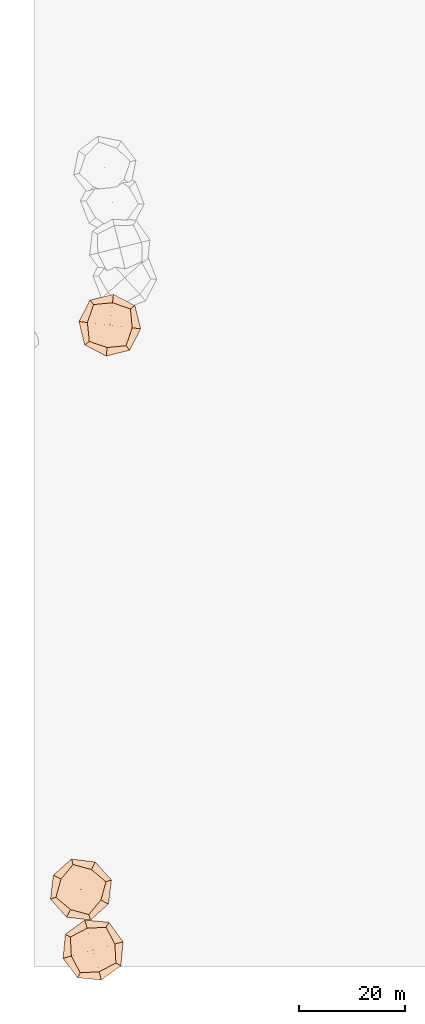
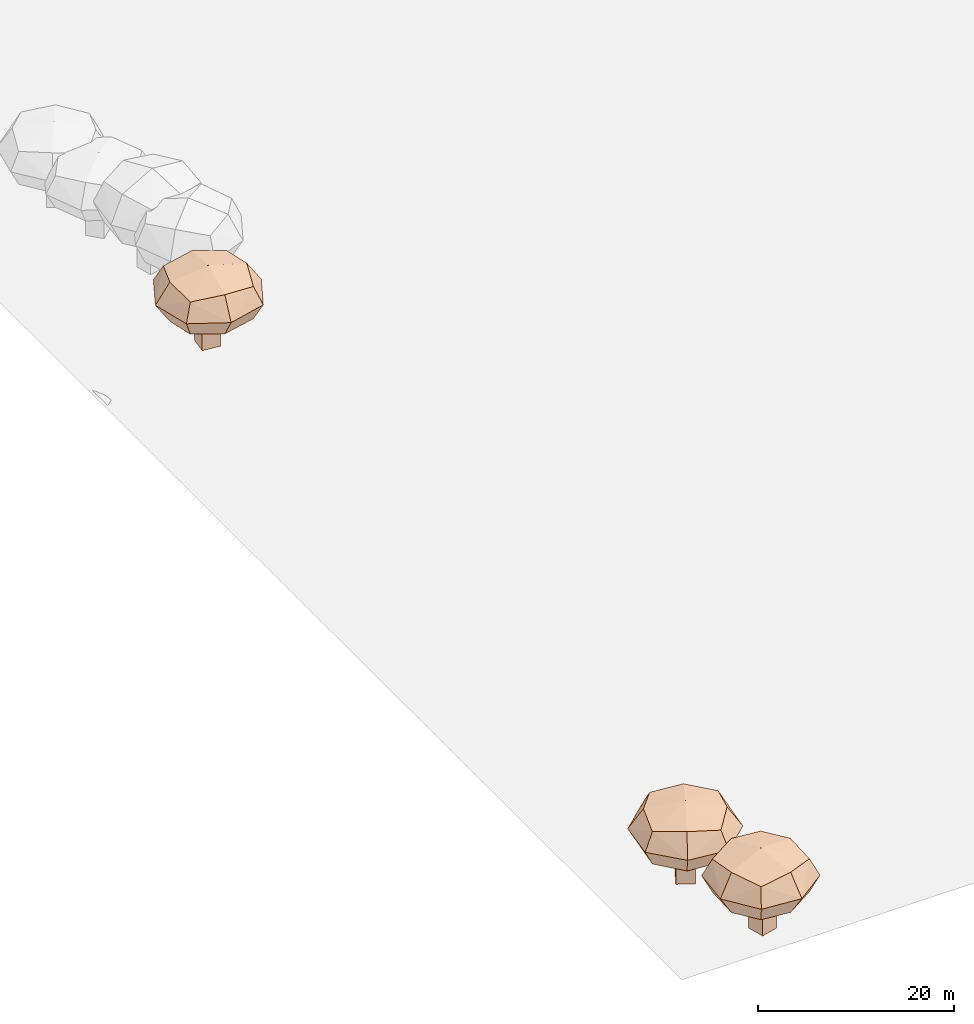
# Not in any storey, part 1 of 92: 3 geographic elements.
"""IFC4 model written with IfcOpenShell, lengths in metres."""

from ifc_helpers import new_model, si_unit, origin_with_axes, place, context, subcontext, project, spatial, triangles, material, element, save


model = new_model("IFC4")

# Units and contexts
model_context = context("Model", 3, precision=1e-05, world=origin_with_axes())
body_context = subcontext(model_context, "Body", "Model", "MODEL_VIEW")
ifc_project = project(units=[si_unit("VOLUMEUNIT", "CUBIC_METRE"), si_unit("LENGTHUNIT", "METRE"), si_unit("AREAUNIT", "SQUARE_METRE")], contexts=[model_context])

# Site
site_placement = place(None, origin_with_axes())
site = spatial("IfcSite", under=ifc_project, at=site_placement)

# Geographic elements
ifc_material = material(Name="tree")
geographic_element_1_placement = place(site_placement, origin_with_axes())
element("IfcGeographicElement", 1, at=geographic_element_1_placement, inside=site, material=ifc_material, Name="cw_instances_tree_201", context=body_context, shape_type="Tessellation", body=[
    triangles([(13.462260745399858, -775.030931593505, 5.714882036367992), (13.462260745399858, -775.030931593505, 5.714882036367992), (13.462260745399858, -775.030931593505, 5.714882036367992), (13.462260745399858, -775.030931593505, 0.0), (13.462260745399858, -775.030931593505, 0.0), (13.462260745399858, -775.030931593505, 0.0), (15.448455822864668, -775.2655144450832, 5.714882036367992), (15.448455822864668, -775.2655144450832, 5.714882036367992), (15.448455822864668, -775.2655144450832, 5.714882036367992), (15.448455822864668, -775.2655144450832, 0.0), (15.448455822864668, -775.2655144450832, 0.0), (15.448455822864668, -775.2655144450832, 0.0), (13.227677893821658, -777.0171266709699, 5.714882036367992), (13.227677893821658, -777.0171266709699, 5.714882036367992), (13.227677893821658, -777.0171266709699, 5.714882036367992), (13.227677893821658, -777.0171266709699, 0.0), (13.227677893821658, -777.0171266709699, 0.0), (13.227677893821658, -777.0171266709699, 0.0), (15.213872971286468, -777.251709522548, 5.714882036367992), (15.213872971286468, -777.251709522548, 5.714882036367992), (15.213872971286468, -777.251709522548, 5.714882036367992), (15.213872971286468, -777.251709522548, 0.0), (15.213872971286468, -777.251709522548, 0.0), (15.213872971286468, -777.251709522548, 0.0), (11.243569686765333, -772.5019902965017, 8.512689542772936), (11.243569686765333, -772.5019902965017, 8.512689542772936), (11.243569686765333, -772.5019902965017, 8.512689542772936), (11.243569686765333, -772.5019902965017, 8.512689542772936), (11.243569686765333, -772.5019902965017, 8.512689542772936), (11.243569686765333, -772.5019902965017, 8.512689542772936), (11.243569238228456, -772.5019900018584, 4.512272277332048), (11.243569238228456, -772.5019900018584, 4.512272277332048), (11.243569238228456, -772.5019900018584, 4.512272277332048), (11.243569238228456, -772.5019900018584, 4.512272277332048), (11.243569238228456, -772.5019900018584, 4.512272277332048), (11.243569238228456, -772.5019900018584, 4.512272277332048), (18.195250827569218, -773.3230298428053, 8.512689542772936), (18.195250827569218, -773.3230298428053, 8.512689542772936), (18.195250827569218, -773.3230298428053, 8.512689542772936), (18.195250827569218, -773.3230298428053, 8.512689542772936), (18.195250827569218, -773.3230298428053, 8.512689542772936), (18.195250827569218, -773.3230298428053, 8.512689542772936), (18.195250827569218, -773.3230298428053, 4.512272277332048), (18.195250827569218, -773.3230298428053, 4.512272277332048), (18.195250827569218, -773.3230298428053, 4.512272277332048), (18.195250827569218, -773.3230298428053, 4.512272277332048), (18.195250827569218, -773.3230298428053, 4.512272277332048), (18.195250827569218, -773.3230298428053, 4.512272277332048), (10.422529312831728, -779.4536723062294, 8.512689542772936), (10.422529312831728, -779.4536723062294, 8.512689542772936), (10.422529312831728, -779.4536723062294, 8.512689542772936), (10.422529312831728, -779.4536723062294, 8.512689542772936), (10.422529312831728, -779.4536723062294, 8.512689542772936), (10.422529312831728, -779.4536723062294, 8.512689542772936), (10.422529369131613, -779.4536718295426, 4.512272277332048), (10.422529369131613, -779.4536718295426, 4.512272277332048), (10.422529369131613, -779.4536718295426, 4.512272277332048), (10.422529369131613, -779.4536718295426, 4.512272277332048), (10.422529369131613, -779.4536718295426, 4.512272277332048), (10.422529369131613, -779.4536718295426, 4.512272277332048), (17.3742111405159, -780.2747121753263, 8.512689542772936), (17.3742111405159, -780.2747121753263, 8.512689542772936), (17.3742111405159, -780.2747121753263, 8.512689542772936), (17.3742111405159, -780.2747121753263, 8.512689542772936), (17.3742111405159, -780.2747121753263, 8.512689542772936), (17.3742111405159, -780.2747121753263, 8.512689542772936), (17.37421090217249, -780.2747121471763, 4.512272277332048), (17.37421090217249, -780.2747121471763, 4.512272277332048), (17.37421090217249, -780.2747121471763, 4.512272277332048), (17.37421090217249, -780.2747121471763, 4.512272277332048), (17.37421090217249, -780.2747121471763, 4.512272277332048), (17.37421090217249, -780.2747121471763, 4.512272277332048), (13.808410659658996, -780.6258731478587, 4.073955600388096), (13.808410659658996, -780.6258731478587, 4.073955600388096), (13.808410659658996, -780.6258731478587, 4.073955600388096), (13.808410659658996, -780.6258731478587, 4.073955600388096), (10.071368602726242, -775.8878715643513, 4.073955600388096), (10.071368602726242, -775.8878715643513, 4.073955600388096), (10.071368602726242, -775.8878715643513, 4.073955600388096), (10.071368602726242, -775.8878715643513, 4.073955600388096), (10.571848088103717, -771.6503500083585, 6.5124812529454355), (10.571848088103717, -771.6503500083585, 6.5124812529454355), (10.571848088103717, -771.6503500083585, 6.5124812529454355), (10.571848088103717, -771.6503500083585, 6.5124812529454355), (18.045932235513668, -781.126352635582, 6.5124812529454355), (18.045932235513668, -781.126352635582, 6.5124812529454355), (18.045932235513668, -781.126352635582, 6.5124812529454355), (18.045932235513668, -781.126352635582, 6.5124812529454355), (19.0468917914888, -772.651308575695, 6.5124812529454355), (19.0468917914888, -772.651308575695, 6.5124812529454355), (19.0468917914888, -772.651308575695, 6.5124812529454355), (19.0468917914888, -772.651308575695, 6.5124812529454355), (9.570889110311283, -780.1253931799298, 6.5124812529454355), (9.570889110311283, -780.1253931799298, 6.5124812529454355), (9.570889110311283, -780.1253931799298, 6.5124812529454355), (9.570889110311283, -780.1253931799298, 6.5124812529454355), (18.546412250984353, -776.8888305984435, 8.951005876823944), (18.546412250984353, -776.8888305984435, 8.951005876823944), (18.546412250984353, -776.8888305984435, 8.951005876823944), (18.546412250984353, -776.8888305984435, 8.951005876823944), (14.809369649568533, -772.1508290211156, 8.951007219821305), (14.809369649568533, -772.1508290211156, 8.951007219821305), (14.809369649568533, -772.1508290211156, 8.951007219821305), (14.809369649568533, -772.1508290211156, 8.951007219821305), (18.54641177836394, -776.8888305929714, 4.073955600388096), (18.54641177836394, -776.8888305929714, 4.073955600388096), (18.54641177836394, -776.8888305929714, 4.073955600388096), (18.54641177836394, -776.8888305929714, 4.073955600388096), (13.808410619935094, -780.625873143167, 8.951005876823944), (13.808410619935094, -780.625873143167, 8.951005876823944), (13.808410619935094, -780.625873143167, 8.951005876823944), (13.808410619935094, -780.625873143167, 8.951005876823944), (10.071368606244986, -775.8878715345583, 8.951007219821305), (10.071368606244986, -775.8878715345583, 8.951007219821305), (10.071368606244986, -775.8878715345583, 8.951007219821305), (10.071368606244986, -775.8878715345583, 8.951007219821305), (14.809369654027414, -772.1508294949089, 4.073955600388096), (14.809369654027414, -772.1508294949089, 4.073955600388096), (14.809369654027414, -772.1508294949089, 4.073955600388096), (14.809369654027414, -772.1508294949089, 4.073955600388096), (14.308890030163946, -776.3883511151015, 9.870856742856473), (14.308890030163946, -776.3883511151015, 9.870856742856473), (14.308890030163946, -776.3883511151015, 9.870856742856473), (14.308890030163946, -776.3883511151015, 9.870856742856473), (14.308890030163946, -776.3883511151015, 9.870856742856473), (14.308890030163946, -776.3883511151015, 9.870856742856473), (14.308890030163946, -776.3883511151015, 9.870856742856473), (14.308890030163946, -776.3883511151015, 9.870856742856473), (20.144869912691682, -777.0776190818432, 6.5124812529454355), (20.144869912691682, -777.0776190818432, 6.5124812529454355), (20.144869912691682, -777.0776190818432, 6.5124812529454355), (20.144869912691682, -777.0776190818432, 6.5124812529454355), (20.144869912691682, -777.0776190818432, 6.5124812529454355), (20.144869912691682, -777.0776190818432, 6.5124812529454355), (20.144869912691682, -777.0776190818432, 6.5124812529454355), (20.144869912691682, -777.0776190818432, 6.5124812529454355), (13.619622146466474, -782.2243308060472, 6.5124812529454355), (13.619622146466474, -782.2243308060472, 6.5124812529454355), (13.619622146466474, -782.2243308060472, 6.5124812529454355), (13.619622146466474, -782.2243308060472, 6.5124812529454355), (13.619622146466474, -782.2243308060472, 6.5124812529454355), (13.619622146466474, -782.2243308060472, 6.5124812529454355), (13.619622146466474, -782.2243308060472, 6.5124812529454355), (13.619622146466474, -782.2243308060472, 6.5124812529454355), (14.308890046584745, -776.3883509760678, 3.1541064202458697), (14.308890046584745, -776.3883509760678, 3.1541064202458697), (14.308890046584745, -776.3883509760678, 3.1541064202458697), (14.308890046584745, -776.3883509760678, 3.1541064202458697), (14.308890046584745, -776.3883509760678, 3.1541064202458697), (14.308890046584745, -776.3883509760678, 3.1541064202458697), (14.308890046584745, -776.3883509760678, 3.1541064202458697), (14.308890046584745, -776.3883509760678, 3.1541064202458697), (14.99815800832433, -770.5523718179537, 6.5124812529454355), (14.99815800832433, -770.5523718179537, 6.5124812529454355), (14.99815800832433, -770.5523718179537, 6.5124812529454355), (14.99815800832433, -770.5523718179537, 6.5124812529454355), (14.99815800832433, -770.5523718179537, 6.5124812529454355), (14.99815800832433, -770.5523718179537, 6.5124812529454355), (14.99815800832433, -770.5523718179537, 6.5124812529454355), (14.99815800832433, -770.5523718179537, 6.5124812529454355), (8.472910458467528, -775.6990830743066, 6.5124812529454355), (8.472910458467528, -775.6990830743066, 6.5124812529454355), (8.472910458467528, -775.6990830743066, 6.5124812529454355), (8.472910458467528, -775.6990830743066, 6.5124812529454355), (8.472910458467528, -775.6990830743066, 6.5124812529454355), (8.472910458467528, -775.6990830743066, 6.5124812529454355), (8.472910458467528, -775.6990830743066, 6.5124812529454355), (8.472910458467528, -775.6990830743066, 6.5124812529454355)], [[15, 8, 2], [7, 24, 11], [19, 16, 22], [4, 23, 17], [3, 12, 6], [14, 5, 18], [26, 127, 101], [54, 123, 114], [124, 66, 98], [128, 38, 102], [45, 133, 108], [40, 135, 89], [130, 63, 88], [131, 70, 105], [68, 141, 73], [61, 140, 86], [137, 49, 93], [142, 56, 74], [59, 145, 75], [31, 149, 79], [150, 43, 107], [146, 71, 76], [35, 154, 120], [30, 157, 83], [158, 42, 91], [153, 47, 119], [58, 164, 77], [51, 162, 96], [167, 28, 81], [165, 33, 80], [15, 21, 8], [7, 20, 24], [19, 13, 16], [4, 10, 23], [3, 9, 12], [14, 1, 5], [25, 115, 126], [53, 111, 121], [122, 112, 65], [125, 99, 37], [46, 90, 136], [39, 100, 134], [132, 97, 64], [129, 87, 69], [67, 85, 138], [62, 110, 144], [143, 109, 50], [139, 94, 55], [60, 78, 147], [32, 117, 151], [152, 118, 44], [148, 106, 72], [36, 84, 160], [29, 104, 156], [155, 103, 41], [159, 92, 48], [57, 95, 161], [52, 113, 163], [166, 116, 27], [168, 82, 34]], closed=True),
])
geographic_element_2_placement = place(site_placement, origin_with_axes())
element("IfcGeographicElement", 2, at=geographic_element_2_placement, inside=site, material=ifc_material, Name="cw_instances_tree_263", context=body_context, shape_type="Tessellation", body=[
    triangles([(8.543818649067786, -881.504173150315, 5.7320743896039135), (8.543818649067786, -881.504173150315, 5.7320743896039135), (8.543818649067786, -881.504173150315, 5.7320743896039135), (8.543818649067786, -881.504173150315, 0.0), (8.543818649067786, -881.504173150315, 0.0), (8.543818649067786, -881.504173150315, 0.0), (10.315363025021764, -882.432413703203, 5.7320743896039135), (10.315363025021764, -882.432413703203, 5.7320743896039135), (10.315363025021764, -882.432413703203, 5.7320743896039135), (10.315363025021764, -882.432413703203, 0.0), (10.315363025021764, -882.432413703203, 0.0), (10.315363025021764, -882.432413703203, 0.0), (7.61557809617978, -883.275717526269, 5.7320743896039135), (7.61557809617978, -883.275717526269, 5.7320743896039135), (7.61557809617978, -883.275717526269, 5.7320743896039135), (7.61557809617978, -883.275717526269, 0.0), (7.61557809617978, -883.275717526269, 0.0), (7.61557809617978, -883.275717526269, 0.0), (9.387122472133758, -884.2039580791569, 5.7320743896039135), (9.387122472133758, -884.2039580791569, 5.7320743896039135), (9.387122472133758, -884.2039580791569, 5.7320743896039135), (9.387122472133758, -884.2039580791569, 0.0), (9.387122472133758, -884.2039580791569, 0.0), (9.387122472133758, -884.2039580791569, 0.0), (7.374240064448537, -878.3497762140125, 8.538298674278316), (7.374240064448537, -878.3497762140125, 8.538298674278316), (7.374240064448537, -878.3497762140125, 8.538298674278316), (7.374240064448537, -878.3497762140125, 8.538298674278316), (7.374240064448537, -878.3497762140125, 8.538298674278316), (7.374240064448537, -878.3497762140125, 8.538298674278316), (7.374239750666753, -878.3497757786495, 4.5258467620536695), (7.374239750666753, -878.3497757786495, 4.5258467620536695), (7.374239750666753, -878.3497757786495, 4.5258467620536695), (7.374239750666753, -878.3497757786495, 4.5258467620536695), (7.374239750666753, -878.3497757786495, 4.5258467620536695), (7.374239750666753, -878.3497757786495, 4.5258467620536695), (13.57464401243677, -881.5986171614544, 8.538298674278316), (13.57464401243677, -881.5986171614544, 8.538298674278316), (13.57464401243677, -881.5986171614544, 8.538298674278316), (13.57464401243677, -881.5986171614544, 8.538298674278316), (13.57464401243677, -881.5986171614544, 8.538298674278316), (13.57464401243677, -881.5986171614544, 8.538298674278316), (13.57464401243677, -881.5986171614544, 4.5258467620536695), (13.57464401243677, -881.5986171614544, 4.5258467620536695), (13.57464401243677, -881.5986171614544, 4.5258467620536695), (13.57464401243677, -881.5986171614544, 4.5258467620536695), (13.57464401243677, -881.5986171614544, 4.5258467620536695), (13.57464401243677, -881.5986171614544, 4.5258467620536695), (4.125398033695262, -884.5501806781755, 8.538298674278316), (4.125398033695262, -884.5501806781755, 8.538298674278316), (4.125398033695262, -884.5501806781755, 8.538298674278316), (4.125398033695262, -884.5501806781755, 8.538298674278316), (4.125398033695262, -884.5501806781755, 8.538298674278316), (4.125398033695262, -884.5501806781755, 8.538298674278316), (4.1253982564729945, -884.5501802530049, 4.5258467620536695), (4.1253982564729945, -884.5501802530049, 4.5258467620536695), (4.1253982564729945, -884.5501802530049, 4.5258467620536695), (4.1253982564729945, -884.5501802530049, 4.5258467620536695), (4.1253982564729945, -884.5501802530049, 4.5258467620536695), (4.1253982564729945, -884.5501802530049, 4.5258467620536695), (10.325802508050607, -887.7990221723693, 8.538298674278316), (10.325802508050607, -887.7990221723693, 8.538298674278316), (10.325802508050607, -887.7990221723693, 8.538298674278316), (10.325802508050607, -887.7990221723693, 8.538298674278316), (10.325802508050607, -887.7990221723693, 8.538298674278316), (10.325802508050607, -887.7990221723693, 8.538298674278316), (10.325802295465282, -887.7990220609804, 4.5258467620536695), (10.325802295465282, -887.7990220609804, 4.5258467620536695), (10.325802295465282, -887.7990220609804, 4.5258467620536695), (10.325802295465282, -887.7990220609804, 4.5258467620536695), (10.325802295465282, -887.7990220609804, 4.5258467620536695), (10.325802295465282, -887.7990220609804, 4.5258467620536695), (6.8696316722635, -886.853966485246, 4.086211476065601), (6.8696316722635, -886.853966485246, 4.086211476065601), (6.8696316722635, -886.853966485246, 4.086211476065601), (6.8696316722635, -886.853966485246, 4.086211476065601), (5.070454059140944, -881.0940096922621, 4.086211476065601), (5.070454059140944, -881.0940096922621, 4.086211476065601), (5.070454059140944, -881.0940096922621, 4.086211476065601), (5.070454059140944, -881.0940096922621, 4.086211476065601), (7.050843295141966, -877.3144426368023, 6.532073062090477), (7.050843295141966, -877.3144426368023, 6.532073062090477), (7.050843295141966, -877.3144426368023, 6.532073062090477), (7.050843295141966, -877.3144426368023, 6.532073062090477), (10.649198745438863, -888.8343557305295, 6.532073062090477), (10.649198745438863, -888.8343557305295, 6.532073062090477), (10.649198745438863, -888.8343557305295, 6.532073062090477), (10.649198745438863, -888.8343557305295, 6.532073062090477), (14.609978102515313, -881.2752209431163, 6.532073062090477), (14.609978102515313, -881.2752209431163, 6.532073062090477), (14.609978102515313, -881.2752209431163, 6.532073062090477), (14.609978102515313, -881.2752209431163, 6.532073062090477), (3.0900647952927054, -884.8735768008684, 6.532073062090477), (3.0900647952927054, -884.8735768008684, 6.532073062090477), (3.0900647952927054, -884.8735768008684, 6.532073062090477), (3.0900647952927054, -884.8735768008684, 6.532073062090477), (12.629588648377762, -885.0547884148891, 8.9779336163419), (12.629588648377762, -885.0547884148891, 8.9779336163419), (12.629588648377762, -885.0547884148891, 8.9779336163419), (12.629588648377762, -885.0547884148891, 8.9779336163419), (10.830410524449807, -879.2948314332843, 8.977934963379463), (10.830410524449807, -879.2948314332843, 8.977934963379463), (10.830410524449807, -879.2948314332843, 8.977934963379463), (10.830410524449807, -879.2948314332843, 8.977934963379463), (12.62958820885882, -885.0547882410413, 4.086211476065601), (12.62958820885882, -885.0547882410413, 4.086211476065601), (12.62958820885882, -885.0547882410413, 4.086211476065601), (12.62958820885882, -885.0547882410413, 4.086211476065601), (6.8696316368326125, -886.8539664666813, 8.9779336163419), (6.8696316368326125, -886.8539664666813, 8.9779336163419), (6.8696316368326125, -886.8539664666813, 8.9779336163419), (6.8696316368326125, -886.8539664666813, 8.9779336163419), (5.070454073064552, -881.094009665689, 8.977934963379463), (5.070454073064552, -881.094009665689, 8.977934963379463), (5.070454073064552, -881.094009665689, 8.977934963379463), (5.070454073064552, -881.094009665689, 8.977934963379463), (10.830410359459608, -879.2948318774445, 4.086211476065601), (10.830410359459608, -879.2948318774445, 4.086211476065601), (10.830410359459608, -879.2948318774445, 4.086211476065601), (10.830410359459608, -879.2948318774445, 4.086211476065601), (8.850020971178578, -883.0743989434305, 9.900551713773531), (8.850020971178578, -883.0743989434305, 9.900551713773531), (8.850020971178578, -883.0743989434305, 9.900551713773531), (8.850020971178578, -883.0743989434305, 9.900551713773531), (8.850020971178578, -883.0743989434305, 9.900551713773531), (8.850020971178578, -883.0743989434305, 9.900551713773531), (8.850020971178578, -883.0743989434305, 9.900551713773531), (8.850020971178578, -883.0743989434305, 9.900551713773531), (14.05529889855752, -885.8018213929213, 6.532073062090477), (14.05529889855752, -885.8018213929213, 6.532073062090477), (14.05529889855752, -885.8018213929213, 6.532073062090477), (14.05529889855752, -885.8018213929213, 6.532073062090477), (14.05529889855752, -885.8018213929213, 6.532073062090477), (14.05529889855752, -885.8018213929213, 6.532073062090477), (14.05529889855752, -885.8018213929213, 6.532073062090477), (14.05529889855752, -885.8018213929213, 6.532073062090477), (6.122598667658213, -888.2796767215023, 6.532073062090477), (6.122598667658213, -888.2796767215023, 6.532073062090477), (6.122598667658213, -888.2796767215023, 6.532073062090477), (6.122598667658213, -888.2796767215023, 6.532073062090477), (6.122598667658213, -888.2796767215023, 6.532073062090477), (6.122598667658213, -888.2796767215023, 6.532073062090477), (6.122598667658213, -888.2796767215023, 6.532073062090477), (6.122598667658213, -888.2796767215023, 6.532073062090477), (8.850021036155416, -883.0743988194224, 3.1635950695960173), (8.850021036155416, -883.0743988194224, 3.1635950695960173), (8.850021036155416, -883.0743988194224, 3.1635950695960173), (8.850021036155416, -883.0743988194224, 3.1635950695960173), (8.850021036155416, -883.0743988194224, 3.1635950695960173), (8.850021036155416, -883.0743988194224, 3.1635950695960173), (8.850021036155416, -883.0743988194224, 3.1635950695960173), (8.850021036155416, -883.0743988194224, 3.1635950695960173), (11.577443222341344, -877.869121566929, 6.532073062090477), (11.577443222341344, -877.869121566929, 6.532073062090477), (11.577443222341344, -877.869121566929, 6.532073062090477), (11.577443222341344, -877.869121566929, 6.532073062090477), (11.577443222341344, -877.869121566929, 6.532073062090477), (11.577443222341344, -877.869121566929, 6.532073062090477), (11.577443222341344, -877.869121566929, 6.532073062090477), (11.577443222341344, -877.869121566929, 6.532073062090477), (3.6447433605845214, -880.3469765357409, 6.532073062090477), (3.6447433605845214, -880.3469765357409, 6.532073062090477), (3.6447433605845214, -880.3469765357409, 6.532073062090477), (3.6447433605845214, -880.3469765357409, 6.532073062090477), (3.6447433605845214, -880.3469765357409, 6.532073062090477), (3.6447433605845214, -880.3469765357409, 6.532073062090477), (3.6447433605845214, -880.3469765357409, 6.532073062090477), (3.6447433605845214, -880.3469765357409, 6.532073062090477)], [[15, 8, 2], [7, 24, 11], [19, 16, 22], [4, 23, 17], [3, 12, 6], [14, 5, 18], [26, 127, 101], [54, 123, 114], [124, 66, 98], [128, 38, 102], [45, 133, 108], [40, 135, 89], [130, 63, 88], [131, 70, 105], [68, 141, 73], [61, 140, 86], [137, 49, 93], [142, 56, 74], [59, 145, 75], [31, 149, 79], [150, 43, 107], [146, 71, 76], [35, 154, 120], [30, 157, 83], [158, 42, 91], [153, 47, 119], [58, 164, 77], [51, 162, 96], [167, 28, 81], [165, 33, 80], [15, 21, 8], [7, 20, 24], [19, 13, 16], [4, 10, 23], [3, 9, 12], [14, 1, 5], [25, 115, 126], [53, 111, 121], [122, 112, 65], [125, 99, 37], [46, 90, 136], [39, 100, 134], [132, 97, 64], [129, 87, 69], [67, 85, 138], [62, 110, 144], [143, 109, 50], [139, 94, 55], [60, 78, 147], [32, 117, 151], [152, 118, 44], [148, 106, 72], [36, 84, 160], [29, 104, 156], [155, 103, 41], [159, 92, 48], [57, 95, 161], [52, 113, 163], [166, 116, 27], [168, 82, 34]], closed=True),
])
geographic_element_3_placement = place(site_placement, origin_with_axes())
element("IfcGeographicElement", 3, at=geographic_element_3_placement, inside=site, material=ifc_material, Name="cw_instances_tree_266", context=body_context, shape_type="Tessellation", body=[
    triangles([(12.088299995210756, -893.2076391180938, 5.860105220273152), (12.088299995210756, -893.2076391180938, 5.860105220273152), (12.088299995210756, -893.2076391180938, 5.860105220273152), (12.088299995210756, -893.2076391180938, 0.0), (12.088299995210756, -893.2076391180938, 0.0), (12.088299995210756, -893.2076391180938, 0.0), (12.61907132279875, -895.1359237956791, 5.860105220273152), (12.61907132279875, -895.1359237956791, 5.860105220273152), (12.61907132279875, -895.1359237956791, 5.860105220273152), (12.61907132279875, -895.1359237956791, 0.0), (12.61907132279875, -895.1359237956791, 0.0), (12.61907132279875, -895.1359237956791, 0.0), (10.160015317625394, -893.7384104456818, 5.860105220273152), (10.160015317625394, -893.7384104456818, 5.860105220273152), (10.160015317625394, -893.7384104456818, 5.860105220273152), (10.160015317625394, -893.7384104456818, 0.0), (10.160015317625394, -893.7384104456818, 0.0), (10.160015317625394, -893.7384104456818, 0.0), (10.690786645213388, -895.6666951232671, 5.860105220273152), (10.690786645213388, -895.6666951232671, 5.860105220273152), (10.690786645213388, -895.6666951232671, 5.860105220273152), (10.690786645213388, -895.6666951232671, 0.0), (10.690786645213388, -895.6666951232671, 0.0), (10.690786645213388, -895.6666951232671, 0.0), (13.595363210061482, -890.1998335120418, 8.72900894729092), (13.595363210061482, -890.1998335120418, 8.72900894729092), (13.595363210061482, -890.1998335120418, 8.72900894729092), (13.595363210061482, -890.1998335120418, 8.72900894729092), (13.595363210061482, -890.1998335120418, 8.72900894729092), (13.595363210061482, -890.1998335120418, 8.72900894729092), (13.595363314070525, -890.1998329855609, 4.626935457182669), (13.595363314070525, -890.1998329855609, 4.626935457182669), (13.595363314070525, -890.1998329855609, 4.626935457182669), (13.595363314070525, -890.1998329855609, 4.626935457182669), (13.595363314070525, -890.1998329855609, 4.626935457182669), (13.595363314070525, -890.1998329855609, 4.626935457182669), (15.45306264481956, -896.9488282097802, 8.72900894729092), (15.45306264481956, -896.9488282097802, 8.72900894729092), (15.45306264481956, -896.9488282097802, 8.72900894729092), (15.45306264481956, -896.9488282097802, 8.72900894729092), (15.45306264481956, -896.9488282097802, 8.72900894729092), (15.45306264481956, -896.9488282097802, 8.72900894729092), (15.45306264481956, -896.9488282097802, 4.626935457182669), (15.45306264481956, -896.9488282097802, 4.626935457182669), (15.45306264481956, -896.9488282097802, 4.626935457182669), (15.45306264481956, -896.9488282097802, 4.626935457182669), (15.45306264481956, -896.9488282097802, 4.626935457182669), (15.45306264481956, -896.9488282097802, 4.626935457182669), (6.846367395668661, -892.0575325073876, 8.72900894729092), (6.846367395668661, -892.0575325073876, 8.72900894729092), (6.846367395668661, -892.0575325073876, 8.72900894729092), (6.846367395668661, -892.0575325073876, 8.72900894729092), (6.846367395668661, -892.0575325073876, 8.72900894729092), (6.846367395668661, -892.0575325073876, 8.72900894729092), (6.8463678584569845, -892.0575323800025, 4.626935457182669), (6.8463678584569845, -892.0575323800025, 4.626935457182669), (6.8463678584569845, -892.0575323800025, 4.626935457182669), (6.8463678584569845, -892.0575323800025, 4.626935457182669), (6.8463678584569845, -892.0575323800025, 4.626935457182669), (6.8463678584569845, -892.0575323800025, 4.626935457182669), (8.704066790110257, -898.8065279630011, 8.72900894729092), (8.704066790110257, -898.8065279630011, 8.72900894729092), (8.704066790110257, -898.8065279630011, 8.72900894729092), (8.704066790110257, -898.8065279630011, 8.72900894729092), (8.704066790110257, -898.8065279630011, 8.72900894729092), (8.704066790110257, -898.8065279630011, 8.72900894729092), (8.704066726417697, -898.8065277316069, 4.626935457182669), (8.704066726417697, -898.8065277316069, 4.626935457182669), (8.704066726417697, -898.8065277316069, 4.626935457182669), (8.704066726417697, -898.8065277316069, 4.626935457182669), (8.704066726417697, -898.8065277316069, 4.626935457182669), (8.704066726417697, -898.8065277316069, 4.626935457182669), (7.035744103706115, -895.6355743979141, 4.177480537492943), (7.035744103706115, -895.6355743979141, 4.177480537492943), (7.035744103706115, -895.6355743979141, 4.177480537492943), (7.035744103706115, -895.6355743979141, 4.177480537492943), (10.01732130139573, -890.3892099657744, 4.177480537492943), (10.01732130139573, -890.3892099657744, 4.177480537492943), (10.01732130139573, -890.3892099657744, 4.177480537492943), (10.01732130139573, -890.3892099657744, 4.177480537492943), (14.13129176686891, -889.2568161906232, 6.677972553843128), (14.13129176686891, -889.2568161906232, 6.677972553843128), (14.13129176686891, -889.2568161906232, 6.677972553843128), (14.13129176686891, -889.2568161906232, 6.677972553843128), (8.168137884164972, -899.7495448826701, 6.677972553843128), (8.168137884164972, -899.7495448826701, 6.677972553843128), (8.168137884164972, -899.7495448826701, 6.677972553843128), (8.168137884164972, -899.7495448826701, 6.677972553843128), (16.396079913626355, -897.4847575174751, 6.677972553843128), (16.396079913626355, -897.4847575174751, 6.677972553843128), (16.396079913626355, -897.4847575174751, 6.677972553843128), (16.396079913626355, -897.4847575174751, 6.677972553843128), (5.90335077807401, -891.5216037568487, 6.677972553843128), (5.90335077807401, -891.5216037568487, 6.677972553843128), (5.90335077807401, -891.5216037568487, 6.677972553843128), (5.90335077807401, -891.5216037568487, 6.677972553843128), (12.282108995006277, -898.6171514173576, 9.17846351537431), (12.282108995006277, -898.6171514173576, 9.17846351537431), (12.282108995006277, -898.6171514173576, 9.17846351537431), (12.282108995006277, -898.6171514173576, 9.17846351537431), (15.26368598189767, -893.370786483158, 9.17846489249912), (15.26368598189767, -893.370786483158, 9.17846489249912), (15.26368598189767, -893.370786483158, 9.17846489249912), (15.26368598189767, -893.370786483158, 9.17846489249912), (12.282108822067897, -898.6171509774799, 4.177480537492943), (12.282108822067897, -898.6171509774799, 4.177480537492943), (12.282108822067897, -898.6171509774799, 4.177480537492943), (12.282108822067897, -898.6171509774799, 4.177480537492943), (7.035744093090688, -895.6355743593483, 9.17846351537431), (7.035744093090688, -895.6355743593483, 9.17846351537431), (7.035744093090688, -895.6355743593483, 9.17846351537431), (7.035744093090688, -895.6355743593483, 9.17846351537431), (10.017321330320001, -890.3892099578128, 9.17846489249912), (10.017321330320001, -890.3892099578128, 9.17846489249912), (10.017321330320001, -890.3892099578128, 9.17846489249912), (10.017321330320001, -890.3892099578128, 9.17846489249912), (15.263685544673912, -893.3707866657378, 4.177480537492943), (15.263685544673912, -893.3707866657378, 4.177480537492943), (15.263685544673912, -893.3707866657378, 4.177480537492943), (15.263685544673912, -893.3707866657378, 4.177480537492943), (11.149714967569208, -894.5031803367813, 10.121689084617346), (11.149714967569208, -894.5031803367813, 10.121689084617346), (11.149714967569208, -894.5031803367813, 10.121689084617346), (11.149714967569208, -894.5031803367813, 10.121689084617346), (11.149714967569208, -894.5031803367813, 10.121689084617346), (11.149714967569208, -894.5031803367813, 10.121689084617346), (11.149714967569208, -894.5031803367813, 10.121689084617346), (11.149714967569208, -894.5031803367813, 10.121689084617346), (12.709265171569013, -900.1690037262322, 6.677972553843128), (12.709265171569013, -900.1690037262322, 6.677972553843128), (12.709265171569013, -900.1690037262322, 6.677972553843128), (12.709265171569013, -900.1690037262322, 6.677972553843128), (12.709265171569013, -900.1690037262322, 6.677972553843128), (12.709265171569013, -900.1690037262322, 6.677972553843128), (12.709265171569013, -900.1690037262322, 6.677972553843128), (12.709265171569013, -900.1690037262322, 6.677972553843128), (5.48389178686993, -896.0627305455525, 6.677972553843128), (5.48389178686993, -896.0627305455525, 6.677972553843128), (5.48389178686993, -896.0627305455525, 6.677972553843128), (5.48389178686993, -896.0627305455525, 6.677972553843128), (5.48389178686993, -896.0627305455525, 6.677972553843128), (5.48389178686993, -896.0627305455525, 6.677972553843128), (5.48389178686993, -896.0627305455525, 6.677972553843128), (5.48389178686993, -896.0627305455525, 6.677972553843128), (11.149715102549136, -894.5031802996273, 3.234256696981051), (11.149715102549136, -894.5031802996273, 3.234256696981051), (11.149715102549136, -894.5031802996273, 3.234256696981051), (11.149715102549136, -894.5031802996273, 3.234256696981051), (11.149715102549136, -894.5031802996273, 3.234256696981051), (11.149715102549136, -894.5031802996273, 3.234256696981051), (11.149715102549136, -894.5031802996273, 3.234256696981051), (11.149715102549136, -894.5031802996273, 3.234256696981051), (16.81553781904839, -892.9436303638365, 6.677972553843128), (16.81553781904839, -892.9436303638365, 6.677972553843128), (16.81553781904839, -892.9436303638365, 6.677972553843128), (16.81553781904839, -892.9436303638365, 6.677972553843128), (16.81553781904839, -892.9436303638365, 6.677972553843128), (16.81553781904839, -892.9436303638365, 6.677972553843128), (16.81553781904839, -892.9436303638365, 6.677972553843128), (16.81553781904839, -892.9436303638365, 6.677972553843128), (9.590164949240759, -888.8373572073807, 6.677972553843128), (9.590164949240759, -888.8373572073807, 6.677972553843128), (9.590164949240759, -888.8373572073807, 6.677972553843128), (9.590164949240759, -888.8373572073807, 6.677972553843128), (9.590164949240759, -888.8373572073807, 6.677972553843128), (9.590164949240759, -888.8373572073807, 6.677972553843128), (9.590164949240759, -888.8373572073807, 6.677972553843128), (9.590164949240759, -888.8373572073807, 6.677972553843128)], [[15, 8, 2], [7, 24, 11], [19, 16, 22], [4, 23, 17], [3, 12, 6], [14, 5, 18], [26, 127, 101], [54, 123, 114], [124, 66, 98], [128, 38, 102], [45, 133, 108], [40, 135, 89], [130, 63, 88], [131, 70, 105], [68, 141, 73], [61, 140, 86], [137, 49, 93], [142, 56, 74], [59, 145, 75], [31, 149, 79], [150, 43, 107], [146, 71, 76], [35, 154, 120], [30, 157, 83], [158, 42, 91], [153, 47, 119], [58, 164, 77], [51, 162, 96], [167, 28, 81], [165, 33, 80], [15, 21, 8], [7, 20, 24], [19, 13, 16], [4, 10, 23], [3, 9, 12], [14, 1, 5], [25, 115, 126], [53, 111, 121], [122, 112, 65], [125, 99, 37], [46, 90, 136], [39, 100, 134], [132, 97, 64], [129, 87, 69], [67, 85, 138], [62, 110, 144], [143, 109, 50], [139, 94, 55], [60, 78, 147], [32, 117, 151], [152, 118, 44], [148, 106, 72], [36, 84, 160], [29, 104, 156], [155, 103, 41], [159, 92, 48], [57, 95, 161], [52, 113, 163], [166, 116, 27], [168, 82, 34]], closed=True),
])

save(model, "model.ifc")
